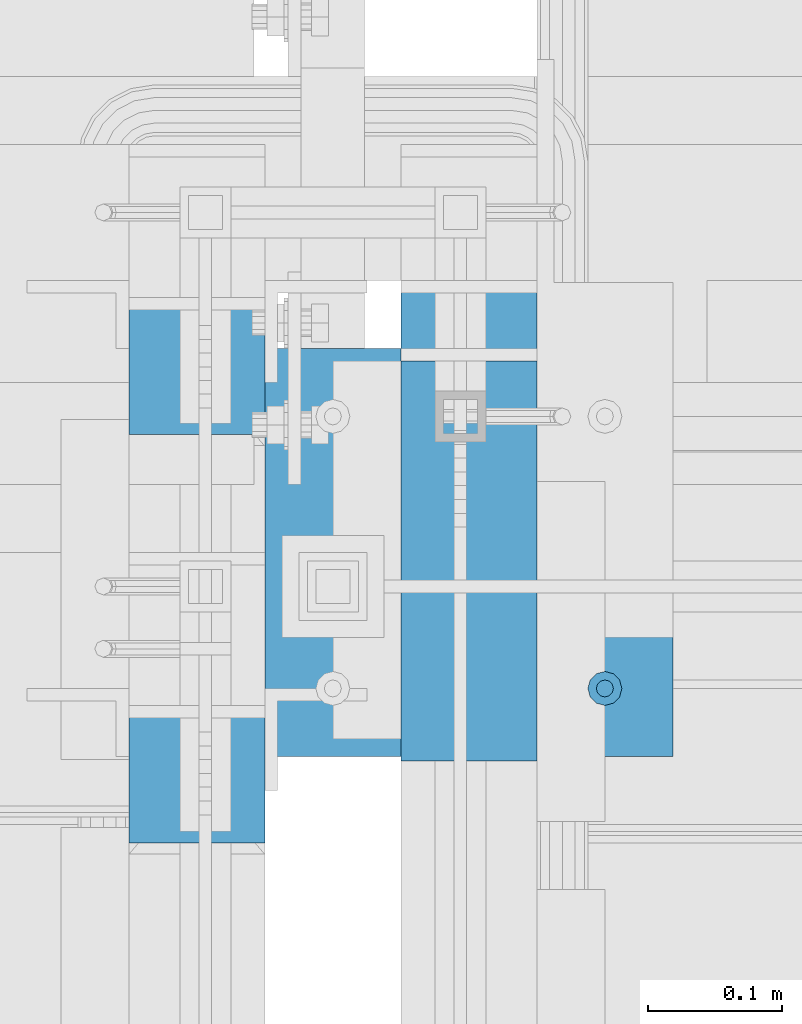
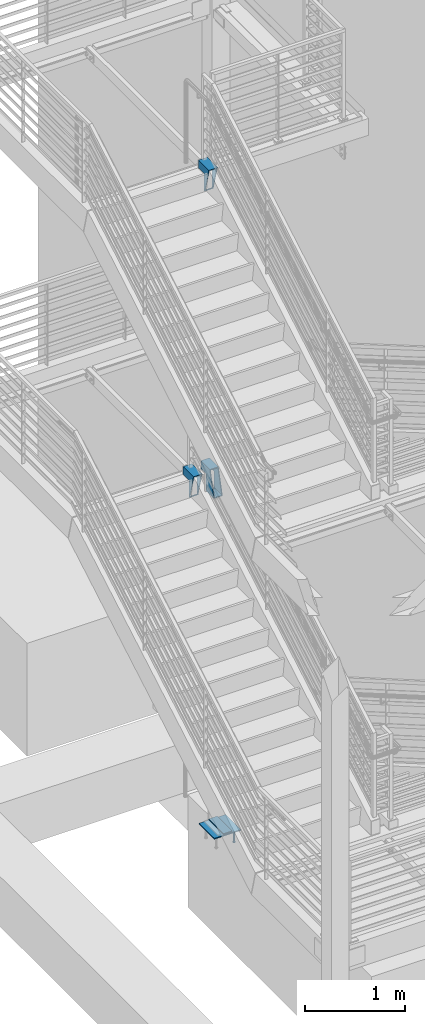
# One storey, part 866 of 1179: 6 beams, 5 elements without a shape of their own.
"""IFC2X3 building model written with IfcOpenShell, lengths in millimetres."""

from ifc_helpers import new_model, si_unit, frame, origin_with_axes, place, context, subcontext, project, spatial, faceted_brep, material, type_object, element, aggregate, save


model = new_model("IFC2X3")

# Units and contexts
model_context = context("Model", 3, precision=1e-05, world=origin_with_axes())
body_context = subcontext(model_context, "Body", "Model", "MODEL_VIEW")
ifc_project = project(units=[si_unit("LENGTHUNIT", "METRE", prefix="MILLI"), si_unit("AREAUNIT", "SQUARE_METRE"), si_unit("VOLUMEUNIT", "CUBIC_METRE"), si_unit("MASSUNIT", "GRAM", prefix="KILO"), si_unit("TIMEUNIT", "SECOND"), si_unit("PLANEANGLEUNIT", "RADIAN"), si_unit("SOLIDANGLEUNIT", "STERADIAN"), si_unit("THERMODYNAMICTEMPERATUREUNIT", "DEGREE_CELSIUS"), si_unit("LUMINOUSINTENSITYUNIT", "LUMEN")], contexts=[model_context])

# Site, building, storey
site_placement = place(None, origin_with_axes())
site = spatial("IfcSite", under=ifc_project, at=site_placement, CompositionType="ELEMENT")
building_placement = place(site_placement, origin_with_axes())
building = spatial("IfcBuilding", under=site, at=building_placement, Name="Undefined", CompositionType="ELEMENT")
storey_placement = place(building_placement, origin_with_axes())
storey = spatial("IfcBuildingStorey", under=building, at=storey_placement, Name="Undefined", CompositionType="ELEMENT", Elevation=0.0)

# Assembly, beam
assembly_1_placement = place(storey_placement, origin_with_axes())
assembly_1 = element("IfcElementAssembly", 1, at=assembly_1_placement, inside=storey, Name="EMBED", AssemblyPlace="NOTDEFINED", PredefinedType="RIGID_FRAME")
ifc_material_1 = material(Name="STEEL/A108")
beam_type_1 = type_object("IfcBeamType", Name="STUD_1/2-DIA", PredefinedType="NOTDEFINED")
beam_1_placement = place(assembly_1_placement, frame((-1549.40000000632, 35039.3000000001, -12.6999996742202), z_axis=(0.0, 1.0, 0.0), x_axis=(0.0, 0.0, -1.0)))
beam_1 = element("IfcBeam", 2, at=beam_1_placement, type_object=beam_type_1, material=ifc_material_1, Name="STUD", ObjectType="STUD_1/2-DIA", context=body_context, shape_type="Brep", body=[
    faceted_brep([(0.0, -3.1800000667572, 5.5), (0.0, -5.5, 3.1800000667572), (141.732, -5.5, 3.1800000667572), (141.732, -3.1800000667572, 5.5), (0.0, -6.34999999999854, 0.0), (141.732, -6.34999990463257, 0.0), (0.0, -5.5, -3.1800000667572), (141.732, -5.5, -3.1800000667572), (0.0, -3.1800000667572, -5.5), (141.732, -3.1800000667572, -5.5), (0.0, 0.0, -6.34999999999991), (141.732, 0.0, -6.34999990463257), (0.0, 3.1800000667572, -5.5), (141.732, 3.1800000667572, -5.5), (0.0, 5.5, -3.1800000667572), (141.732, 5.5, -3.1800000667572), (0.0, 6.34999999999854, 0.0), (141.732, 6.34999990463257, 0.0), (0.0, 5.5, 3.1800000667572), (141.732, 5.5, 3.1800000667572), (0.0, 3.1800000667572, 5.5), (141.732, 3.1800000667572, 5.5), (0.0, 0.0, 6.34999999999991), (141.732, 0.0, 6.34999990463257), (144.78, -10.9899997711182, 6.34999990463257), (144.78, -6.34000015258789, 10.9899997711182), (144.78, -12.6999998092651, 0.0), (144.78, -10.9899997711182, -6.34999990463257), (144.78, -6.34000015258789, -10.9899997711182), (144.78, 0.0, -12.6899995803833), (144.78, 6.34000015258789, -10.9899997711182), (144.78, 10.9899997711182, -6.34999990463257), (144.78, 12.6999998092651, 0.0), (144.78, 10.9899997711182, 6.34999990463257), (144.78, 6.34000015258789, 10.9899997711182), (144.78, 0.0, 12.6899995803833), (152.4, -10.9899997711182, 6.34999990463257), (152.4, -6.34000015258789, 10.9899997711182), (152.4, -12.6999998092651, 0.0), (152.4, -10.9899997711182, -6.34999990463257), (152.4, -6.34000015258789, -10.9899997711182), (152.4, 0.0, -12.6899995803833), (152.4, 6.34000015258789, -10.9899997711182), (152.4, 10.9899997711182, -6.34999990463257), (152.4, 12.6999998092651, 0.0), (152.4, 10.9899997711182, 6.34999990463257), (152.4, 6.34000015258789, 10.9899997711182), (152.4, 0.0, 12.6899995803833)], [[[0, 1, 2, 3]], [[1, 4, 5, 2]], [[4, 6, 7, 5]], [[6, 8, 9, 7]], [[8, 10, 11, 9]], [[10, 12, 13, 11]], [[12, 14, 15, 13]], [[14, 16, 17, 15]], [[16, 18, 19, 17]], [[18, 20, 21, 19]], [[20, 22, 23, 21]], [[22, 0, 3, 23]], [[22, 20, 18, 16, 14, 12, 10, 8, 6, 4, 1, 0]], [[3, 2, 24, 25]], [[2, 5, 26, 24]], [[5, 7, 27, 26]], [[7, 9, 28, 27]], [[9, 11, 29, 28]], [[11, 13, 30, 29]], [[13, 15, 31, 30]], [[15, 17, 32, 31]], [[17, 19, 33, 32]], [[19, 21, 34, 33]], [[21, 23, 35, 34]], [[23, 3, 25, 35]], [[25, 24, 36, 37]], [[24, 26, 38, 36]], [[26, 27, 39, 38]], [[27, 28, 40, 39]], [[28, 29, 41, 40]], [[29, 30, 42, 41]], [[30, 31, 43, 42]], [[31, 32, 44, 43]], [[32, 33, 45, 44]], [[33, 34, 46, 45]], [[34, 35, 47, 46]], [[35, 25, 37, 47]], [[38, 39, 40, 41, 42, 43, 44, 45, 46, 47, 37, 36]]]),
])

assembly_2_placement = place(storey_placement, origin_with_axes())
assembly_2 = element("IfcElementAssembly", 3, at=assembly_2_placement, inside=storey, Name="STRINGER", AssemblyPlace="NOTDEFINED", PredefinedType="RIGID_FRAME")
ifc_material_2 = material(Name="STEEL/A36")
beam_type_2 = type_object("IfcBeamType", PredefinedType="NOTDEFINED")
beam_2_placement = place(assembly_2_placement, frame((-1651.00000000632, 34985.0008651989, 17.7800144842052), z_axis=(-1.0, 0.0, 0.0), x_axis=(0.0, 0.999999999999027, 1.39499999999652e-06)))
beam_2 = element("IfcBeam", 4, at=beam_2_placement, type_object=beam_type_2, material=ifc_material_2, Name="PLATE", context=body_context, shape_type="Brep", body=[
    faceted_brep([(0.0, 4.76249999999982, -50.7999999999993), (0.0, 4.76249999999982, 50.7999999999993), (298.774139809131, 4.76250000000038, 50.8), (298.774139809131, 4.76250000000038, -50.8), (0.0, -4.76249999999982, 50.7999999999993), (298.774139809109, -4.7624999999996, 50.8), (0.0, -4.76249999999982, -50.7999999999993), (298.774139809109, -4.7624999999996, -50.8)], [[[0, 1, 2, 3]], [[1, 4, 5, 2]], [[4, 6, 7, 5]], [[6, 0, 3, 7]], [[5, 7, 3, 2]], [[6, 4, 1, 0]]]),
])
aggregate(assembly_2, [beam_2])

assembly_3_placement = place(storey_placement, origin_with_axes())
assembly_3 = element("IfcElementAssembly", 5, at=assembly_3_placement, inside=storey, Name="STRINGER", AssemblyPlace="NOTDEFINED", PredefinedType="RIGID_FRAME")
ifc_material_3 = material()
beam_type_3 = type_object("IfcBeamType", Name="HSS12X4X3/8", PredefinedType="NOTDEFINED")
beam_3_placement = place(assembly_3_placement, frame((-1854.20000000202, 34923.9662636096, 8045.44999999925), z_axis=(0.0, 0.0, 1.0), x_axis=(0.0, 1.0, 0.0)))
beam_3 = element("IfcBeam", 6, at=beam_3_placement, type_object=beam_type_3, material=ifc_material_3, Name="STRINGER", ObjectType="HSS12X4X3/8", context=body_context, shape_type="Brep", body=[
    faceted_brep([(93.108736390408, 41.2750000000001, 57.1500000007454), (93.108736390408, 50.8, 57.1500000007454), (207.408736386758, 50.8, 57.1499999999924), (207.408736386758, 41.2750000000001, 57.1499999999924), (93.1087363904007, -50.8, -152.4), (93.1087363904007, 50.8, -152.4), (93.1087363904007, 41.2750000000001, -142.875), (93.1087363904007, -41.2750000000001, -142.875), (93.108736390408, -41.2750000000001, 57.1500000007454), (93.108736390408, -50.8, 57.1500000007454), (207.408736386758, -41.2750000000001, 57.1499999999924), (207.408736386758, -50.8, 57.1499999999924), (207.408736386758, -50.8, 152.399999999721), (207.408736386758, -41.2750000000001, 142.875), (207.408736386758, 41.2750000000001, 142.875), (207.408736386758, 50.8, 152.4), (0.0, 50.8000000000029, 152.4), (0.0, -50.8000000000029, 152.4), (82.402418237336, -50.8000000000029, -152.4), (82.402418237336, 50.8000000000029, -152.4), (2.57507555327538, 41.2750000000015, 142.875), (2.57507555327538, -41.2750000000015, 142.875), (79.827342666882, -41.2750000000015, -142.875), (79.827342666882, 41.2750000000015, -142.875)], [[[0, 1, 2, 3]], [[4, 5, 1, 0, 6, 7, 8, 9]], [[9, 8, 10, 11]], [[12, 11, 10, 13, 14, 3, 2, 15]], [[16, 17, 12, 15]], [[18, 19, 5, 4]], [[17, 18, 4, 9, 11, 12]], [[1, 5, 19, 16, 15, 2]], [[18, 17, 16, 19], [20, 21, 22, 23]], [[8, 7, 22, 21, 13, 10]], [[23, 22, 7, 6]], [[20, 23, 6, 0, 3, 14]], [[21, 20, 14, 13]]]),
])
aggregate(assembly_3, [beam_3])

assembly_4_placement = place(storey_placement, origin_with_axes())
assembly_4 = element("IfcElementAssembly", 7, at=assembly_4_placement, inside=storey, Name="STRINGER", AssemblyPlace="NOTDEFINED", PredefinedType="RIGID_FRAME")
beam_4_placement = place(assembly_4_placement, frame((-1650.99999999211, 35445.699999351, 4133.84999890191), z_axis=(0.0, 0.0, 1.0), x_axis=(0.0, -1.0, 0.0)))
beam_4 = element("IfcBeam", 8, at=beam_4_placement, type_object=beam_type_3, material=ifc_material_3, Name="STRINGER", ObjectType="HSS12X4X3/8", context=body_context, shape_type="Brep", body=[
    faceted_brep([(9.5249993518446, 41.2750000000001, 57.1500010971959), (9.5249993518446, 50.8, 57.1500010971959), (111.124999348205, 50.8, 57.1500010970904), (111.124999348205, 41.2750000000001, 57.1500010970904), (9.5249993518446, -50.8, 152.4), (9.5249993518446, 50.8, 152.4), (9.5249993518446, 41.2750000000001, 142.875), (9.5249993518446, -41.2750000000001, 142.875), (9.5249993518446, -41.2750000000001, 57.1500010971959), (9.5249993518446, -50.8, 57.1500010971959), (111.124999348205, -41.2750000000001, 57.1500010970904), (111.124999348205, -50.8, 57.1500010970904), (111.124999348205, -41.2750000000001, -142.875), (111.124999348205, 41.2750000000001, -142.875), (111.124999348205, 50.8, -152.4), (111.124999348205, -50.8, -152.4), (271.868682097433, 50.8, -152.4), (271.868682097433, -50.8, -152.4), (189.466263842922, -50.8, 152.4), (189.466263842922, 50.8, 152.4), (192.041339413379, -41.2750000000001, 142.875), (192.041339413379, 41.2750000000001, 142.875), (269.293606526982, 41.2750000000001, -142.875), (269.293606526982, -41.2750000000001, -142.875)], [[[0, 1, 2, 3]], [[4, 5, 1, 0, 6, 7, 8, 9]], [[9, 8, 10, 11]], [[11, 10, 12, 13, 3, 2, 14, 15]], [[16, 17, 15, 14]], [[18, 19, 5, 4]], [[17, 18, 4, 9, 11, 15]], [[5, 19, 16, 14, 2, 1]], [[18, 17, 16, 19], [20, 21, 22, 23]], [[21, 20, 7, 6]], [[22, 21, 6, 0, 3, 13]], [[23, 22, 13, 12]], [[7, 20, 23, 12, 10, 8]]]),
])
aggregate(assembly_4, [beam_4])

assembly_5_placement = place(storey_placement, origin_with_axes())
assembly_5 = element("IfcElementAssembly", 9, at=assembly_5_placement, inside=storey, Name="STRINGER", AssemblyPlace="NOTDEFINED", PredefinedType="RIGID_FRAME")
beam_5_placement = place(assembly_5_placement, frame((-1854.19999999986, 35228.8546573802, 4133.85000000005), z_axis=(0.0, 0.0, 1.0), x_axis=(0.0, 1.0, 0.0)))
beam_5 = element("IfcBeam", 10, at=beam_5_placement, type_object=beam_type_3, material=ifc_material_3, Name="STRINGER", ObjectType="HSS12X4X3/8", context=body_context, shape_type="Brep", body=[
    faceted_brep([(93.0203426225926, 41.2750000000001, 57.1499999990692), (93.0203426225926, 50.8, 57.1499999990692), (207.32034261895, 50.8, 57.1499999994139), (207.32034261895, 41.2750000000001, 57.1499999994139), (93.0203426225926, -50.8, -152.4), (93.0203426225926, 50.8, -152.4), (93.0203426225926, 41.2750000000001, -142.875), (93.0203426225926, -41.2750000000001, -142.875), (93.0203426225926, -41.2750000000001, 57.1499999990692), (93.0203426225926, -50.8, 57.1499999990692), (207.32034261895, -41.2750000000001, 57.1499999994139), (207.32034261895, -50.8, 57.1499999994139), (207.32034261895, -50.8, 152.399999999145), (207.32034261895, -41.2750000000001, 142.875), (207.32034261895, 41.2750000000001, 142.875), (207.32034261895, 50.8, 152.4), (0.0, 50.8000000000029, 152.4), (0.0, -50.8000000000029, 152.4), (81.8720535463835, -50.8000000000029, -152.4), (81.8720535463835, 50.8000000000029, -152.4), (2.55849975384263, 41.2750000000015, 142.875), (2.55849975384263, -41.2750000000015, 142.875), (79.3135518111412, -41.2750000000015, -142.875), (79.3135518111412, 41.2750000000015, -142.875)], [[[0, 1, 2, 3]], [[4, 5, 1, 0, 6, 7, 8, 9]], [[9, 8, 10, 11]], [[12, 11, 10, 13, 14, 3, 2, 15]], [[16, 17, 12, 15]], [[18, 19, 5, 4]], [[17, 18, 4, 9, 11, 12]], [[1, 5, 19, 16, 15, 2]], [[18, 17, 16, 19], [20, 21, 22, 23]], [[8, 7, 22, 21, 13, 10]], [[23, 22, 7, 6]], [[20, 23, 6, 0, 3, 14]], [[21, 20, 14, 13]]]),
])
aggregate(assembly_5, [beam_5])

# Beam
beam_type_4 = type_object("IfcBeamType", PredefinedType="NOTDEFINED")
beam_6_placement = place(assembly_1_placement, frame((-1498.60000000632, 35140.9, -6.35000000000009), z_axis=(0.0, 1.0, 0.0), x_axis=(-1.0, 0.0, 0.0)))
beam_6 = element("IfcBeam", 11, at=beam_6_placement, type_object=beam_type_4, material=ifc_material_2, Name="EMBED", context=body_context, shape_type="Brep", body=[
    faceted_brep([(0.0, 6.35, -152.400000000001), (0.0, 6.34999999999854, 152.400000000001), (304.799999999999, 6.35, 152.400000000001), (304.799999999999, 6.35, -152.400000000001), (0.0, -6.34999999999854, 152.400000000001), (304.799999999999, -6.35, 152.400000000001), (0.0, -6.35, -152.400000000001), (304.799999999999, -6.35, -152.400000000001)], [[[0, 1, 2, 3]], [[1, 4, 5, 2]], [[4, 6, 7, 5]], [[6, 0, 3, 7]], [[5, 7, 3, 2]], [[6, 4, 1, 0]]]),
])

aggregate(assembly_1, [beam_1, beam_6])

save(model, "model.ifc")
